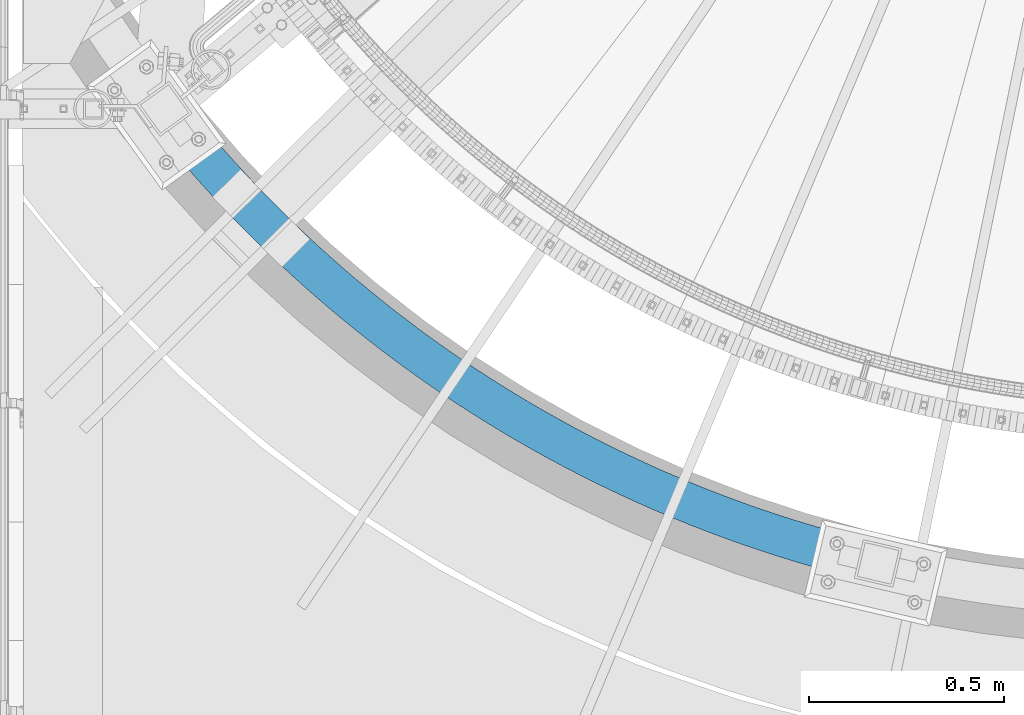
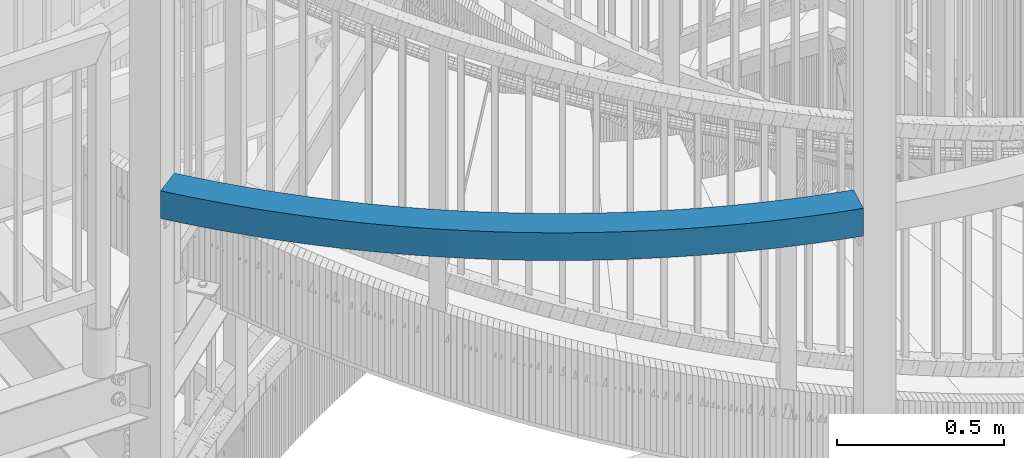
# One storey, part 337 of 975: 1 beam.
"""IFC2X3 building model written with IfcOpenShell, lengths in millimetres."""

from ifc_helpers import new_model, si_unit, frame, origin_with_axes, place, context, subcontext, project, spatial, faceted_brep, material, type_object, element, save


model = new_model("IFC2X3")

# Units and contexts
model_context = context("Model", 3, precision=1e-05, world=origin_with_axes())
body_context = subcontext(model_context, "Body", "Model", "MODEL_VIEW")
ifc_project = project(units=[si_unit("LENGTHUNIT", "METRE", prefix="MILLI"), si_unit("AREAUNIT", "SQUARE_METRE"), si_unit("VOLUMEUNIT", "CUBIC_METRE"), si_unit("MASSUNIT", "GRAM", prefix="KILO"), si_unit("TIMEUNIT", "SECOND"), si_unit("PLANEANGLEUNIT", "RADIAN"), si_unit("SOLIDANGLEUNIT", "STERADIAN"), si_unit("THERMODYNAMICTEMPERATUREUNIT", "DEGREE_CELSIUS"), si_unit("LUMINOUSINTENSITYUNIT", "LUMEN")], contexts=[model_context])

# Site, building, storey
site_placement = place(None, origin_with_axes())
site = spatial("IfcSite", under=ifc_project, at=site_placement, CompositionType="ELEMENT")
building_placement = place(site_placement, origin_with_axes())
building = spatial("IfcBuilding", under=site, at=building_placement, Name="Undefined", CompositionType="ELEMENT")
storey_placement = place(building_placement, origin_with_axes())
storey = spatial("IfcBuildingStorey", under=building, at=storey_placement, Name="Undefined", CompositionType="ELEMENT", Elevation=0.0)

# Beam
ifc_material = material()
beam_type = type_object("IfcBeamType", Name="HSS4X4X3/8", PredefinedType="NOTDEFINED")
beam_placement = place(storey_placement, frame((33982.1142771518, 198.286565354013, 4521.2), z_axis=(0.0, 0.0, 1.0), x_axis=(-0.831867275840489, 0.554974625893584, 0.0)))
element("IfcBeam", 1, at=beam_placement, inside=storey, type_object=beam_type, material=ifc_material, Name="BEAM", ObjectType="HSS4X4X3/8", context=body_context, shape_type="Brep", body=[
    faceted_brep([(2064.52279994458, 26.9212742150994, 50.8000000000002), (2064.52279994458, 26.9212742150994, -50.8000000000002), (2102.18524200268, 15.6378452218232, -50.8000000000002), (2102.18524200268, 15.6378452218232, 50.8000000000002), (2026.72628023623, 37.7470956417674, 50.8000000000002), (2026.72628023623, 37.7470956417674, -50.8000000000002), (1988.80124269562, 48.1137170378279, 50.8000000000002), (1988.80124269562, 48.1137170378279, -50.8000000000002), (1950.75326604555, 58.0196134870021, 50.8000000000002), (1950.75326604555, 58.0196134870021, -50.8000000000002), (1912.58794709301, 67.4633278450383, 50.8000000000002), (1912.58794709301, 67.4633278450383, -50.8000000000002), (1874.31089990586, 76.4434709540656, 50.8000000000002), (1874.31089990586, 76.4434709540656, -50.8000000000002), (1835.92775498707, 84.9587218469242, 50.8000000000002), (1835.92775498707, 84.9587218469242, -50.8000000000002), (1797.44415844641, 93.0078279414774, 50.8000000000002), (1797.44415844641, 93.0078279414774, -50.8000000000002), (1758.86577116999, 100.589605224886, 50.8000000000002), (1758.86577116999, 100.589605224886, -50.8000000000002), (1720.19826798746, 107.702938427748, 50.8000000000002), (1720.19826798746, 107.702938427748, -50.8000000000002), (1681.44733683736, 114.346781188171, 50.8000000000002), (1681.44733683736, 114.346781188171, -50.8000000000002), (1642.61867793034, 120.520156205686, 50.8000000000002), (1642.61867793034, 120.520156205686, -50.8000000000002), (1603.71800291069, 126.222155384992, 50.8000000000002), (1603.71800291069, 126.222155384992, -50.8000000000002), (1564.7510340162, 131.451939969578, 50.8000000000002), (1564.7510340162, 131.451939969578, -50.8000000000002), (1525.7235032364, 136.208740665035, 50.8000000000002), (1525.7235032364, 136.208740665035, -50.8000000000002), (1486.64115146937, 140.491857752302, 50.8000000000002), (1486.64115146937, 140.491857752302, -50.8000000000002), (1447.50972767731, 144.300661190511, 50.8000000000002), (1447.50972767731, 144.300661190511, -50.8000000000002), (1408.33498804084, 147.634590709735, 50.8000000000002), (1408.33498804084, 147.634590709735, -50.8000000000002), (1369.12269511228, 150.493155893342, 50.8000000000002), (1369.12269511228, 150.493155893342, -50.8000000000002), (1329.87861696798, 152.875936250188, 50.8000000000002), (1329.87861696798, 152.875936250188, -50.8000000000002), (1290.60852635988, 154.782581276435, 50.8000000000002), (1290.60852635988, 154.782581276435, -50.8000000000002), (1251.3181998663, 156.212810507124, 50.8000000000002), (1251.3181998663, 156.212810507124, -50.8000000000002), (1212.01341704224, 157.166413557436, 50.8000000000002), (1212.01341704224, 157.166413557436, -50.8000000000002), (1172.69995956921, 157.643250153615, 50.8000000000002), (1172.69995956921, 157.643250153615, -50.8000000000002), (1133.38361040472, 157.643250153633, 50.8000000000002), (1133.38361040472, 157.643250153633, -50.8000000000002), (1094.07015293168, 157.16641355749, 50.8000000000002), (1094.07015293168, 157.16641355749, -50.8000000000002), (1054.76537010762, 156.212810507219, 50.8000000000002), (1054.76537010762, 156.212810507219, -50.8000000000002), (1015.47504361405, 154.782581276566, 50.8000000000002), (1015.47504361405, 154.782581276566, -50.8000000000002), (976.204953005959, 152.875936250359, 50.8000000000002), (976.204953005959, 152.875936250359, -50.8000000000002), (936.960874861674, 150.49315589355, 50.8000000000002), (936.960874861674, 150.49315589355, -50.8000000000002), (897.74858193312, 147.634590709979, 50.8000000000002), (897.74858193312, 147.634590709979, -50.8000000000002), (858.573842296661, 144.300661190799, 50.8000000000002), (858.573842296661, 144.300661190799, -50.8000000000002), (819.442418504615, 140.491857752619, 50.8000000000002), (819.442418504615, 140.491857752619, -50.8000000000002), (780.360066737609, 136.208740665395, 50.8000000000002), (780.360066737609, 136.208740665395, -50.8000000000002), (741.332535957823, 131.451939969971, 50.8000000000002), (741.332535957823, 131.451939969971, -50.8000000000002), (702.365567063356, 126.222155385429, 50.8000000000002), (702.365567063356, 126.222155385429, -50.8000000000002), (663.464892043732, 120.520156206156, 50.8000000000002), (663.464892043732, 120.520156206156, -50.8000000000002), (624.636233136735, 114.34678118868, 50.8000000000002), (624.636233136735, 114.34678118868, -50.8000000000002), (585.885301986655, 107.702938428294, 50.8000000000002), (585.885301986655, 107.702938428294, -50.8000000000002), (547.217798804162, 100.589605225468, 50.8000000000002), (547.217798804162, 100.589605225468, -50.8000000000002), (508.639411527762, 93.0078279420995, 50.8000000000002), (508.639411527762, 93.0078279420995, -50.8000000000002), (470.155814987145, 84.9587218475826, 50.8000000000002), (470.155814987145, 84.9587218475826, -50.8000000000002), (431.772670068382, 76.4434709547604, 50.8000000000002), (431.772670068382, 76.4434709547604, -50.8000000000002), (393.49562288127, 67.4633278457695, 50.8000000000002), (393.49562288127, 67.4633278457695, -50.8000000000002), (355.33030392876, 58.019613487766, 50.8000000000002), (355.33030392876, 58.019613487766, -50.8000000000002), (317.282327278739, 48.1137170386282, 50.8000000000002), (317.282327278739, 48.1137170386282, -50.8000000000002), (279.357289738171, 37.7470956426077, 50.8000000000002), (279.357289738171, 37.7470956426077, -50.8000000000002), (241.560770029864, 26.9212742159798, 50.8000000000002), (241.560770029864, 26.9212742159798, -50.8000000000002), (203.898327971809, 15.6378452227364, 50.8000000000002), (203.898327971809, 15.6378452227364, -50.8000000000002), (166.375503659361, 3.89846844034764, 50.8000000000002), (166.375503659361, 3.89846844034764, -50.8000000000002), (128.997816650288, -8.29512928441181, 50.8000000000002), (128.997816650288, -8.29512928441181, -50.8000000000002), (91.7707651528508, -20.9411542894595, 50.8000000000002), (91.7707651528508, -20.9411542894595, -50.8000000000002), (65.5293185225273, -30.2118531842389, 50.8000000000002), (65.5293185225273, -30.2118531842389, -50.8000000000002), (58.5085467235222, 75.0598083367004, 50.8000000000002), (58.5085467235222, 75.0598083367004, -50.8000000000002), (29.9447402575825, 64.9686554835462, -50.8000000000002), (29.9447402575825, 64.9686554835462, 50.8000000000002), (96.9023636326565, 88.1021834145577, 50.8000000000002), (96.9023636326565, 88.1021834145577, -50.8000000000002), (135.451537252065, 100.677951295078, 50.8000000000002), (135.451537252065, 100.677951295078, -50.8000000000002), (174.150397049354, 112.785262099464, 50.8000000000002), (174.150397049354, 112.785262099464, -50.8000000000002), (212.993250473493, 124.422334858333, 50.8000000000002), (212.993250473493, 124.422334858333, -50.8000000000002), (251.974383792185, 135.587457773683, 50.8000000000002), (251.974383792185, 135.587457773683, -50.8000000000002), (291.088062932333, 146.278988470724, 50.8000000000002), (291.088062932333, 146.278988470724, -50.8000000000002), (330.32853432354, 156.495354239451, 50.8000000000002), (330.32853432354, 156.495354239451, -50.8000000000002), (369.690025744425, 166.235052265984, 50.8000000000002), (369.690025744425, 166.235052265984, -50.8000000000002), (409.166747171734, 175.496649853649, 50.8000000000002), (409.166747171734, 175.496649853649, -50.8000000000002), (448.752891632008, 184.278784633694, 50.8000000000002), (448.752891632008, 184.278784633694, -50.8000000000002), (488.442636055832, 192.580164765735, 50.8000000000002), (488.442636055832, 192.580164765735, -50.8000000000002), (528.230142134355, 200.399569127738, 50.8000000000002), (528.230142134355, 200.399569127738, -50.8000000000002), (568.109557178119, 207.735847495678, 50.8000000000002), (568.109557178119, 207.735847495678, -50.8000000000002), (608.075014977992, 214.587920712729, 50.8000000000002), (608.075014977992, 214.587920712729, -50.8000000000002), (648.120636668053, 220.954780847991, 50.8000000000002), (648.120636668053, 220.954780847991, -50.8000000000002), (688.240531590378, 226.835491344769, 50.8000000000002), (688.240531590378, 226.835491344769, -50.8000000000002), (728.42879816156, 232.229187158337, 50.8000000000002), (728.42879816156, 232.229187158337, -50.8000000000002), (768.679524740801, 237.135074883179, 50.8000000000002), (768.679524740801, 237.135074883179, -50.8000000000002), (808.98679049953, 241.552432869714, 50.8000000000002), (808.98679049953, 241.552432869714, -50.8000000000002), (849.34466629232, 245.480611330429, 50.8000000000002), (849.34466629232, 245.480611330429, -50.8000000000002), (889.7472155291, 248.919032435475, 50.8000000000002), (889.7472155291, 248.919032435475, -50.8000000000002), (930.188495048376, 251.867190397661, 50.8000000000002), (930.188495048376, 251.867190397661, -50.8000000000002), (970.662555991479, 254.324651546856, 50.8000000000002), (970.662555991479, 254.324651546856, -50.8000000000002), (1011.16344467765, 256.291054393772, 50.8000000000002), (1011.16344467765, 256.291054393772, -50.8000000000002), (1051.6852034798, 257.766109683165, 50.8000000000002), (1051.6852034798, 257.766109683165, -50.8000000000002), (1092.22187170087, 258.749600436349, 50.8000000000002), (1092.22187170087, 258.749600436349, -50.8000000000002), (1132.76748645064, 259.241381983138, 50.8000000000002), (1132.76748645064, 259.241381983138, -50.8000000000002), (1173.31608352288, 259.24138198312, 50.8000000000002), (1173.31608352288, 259.24138198312, -50.8000000000002), (1213.86169827265, 258.749600436291, 50.8000000000002), (1213.86169827265, 258.749600436291, -50.8000000000002), (1254.39836649372, 257.766109683067, 50.8000000000002), (1254.39836649372, 257.766109683067, -50.8000000000002), (1294.92012529587, 256.291054393638, 50.8000000000002), (1294.92012529587, 256.291054393638, -50.8000000000002), (1335.42101398206, 254.324651546678, 50.8000000000002), (1335.42101398206, 254.324651546678, -50.8000000000002), (1375.89507492517, 251.867190397446, 50.8000000000002), (1375.89507492517, 251.867190397446, -50.8000000000002), (1416.33635444446, 248.919032435224, 50.8000000000002), (1416.33635444446, 248.919032435224, -50.8000000000002), (1456.73890368125, 245.480611330138, 50.8000000000002), (1456.73890368125, 245.480611330138, -50.8000000000002), (1497.09677947406, 241.552432869383, 50.8000000000002), (1497.09677947406, 241.552432869383, -50.8000000000002), (1537.4040452328, 237.135074882808, 50.8000000000002), (1537.4040452328, 237.135074882808, -50.8000000000002), (1577.65477181207, 232.229187157925, 50.8000000000002), (1577.65477181207, 232.229187157925, -50.8000000000002), (1617.84303838327, 226.835491344322, 50.8000000000002), (1617.84303838327, 226.835491344322, -50.8000000000002), (1657.96293330561, 220.954780847507, 50.8000000000002), (1657.96293330561, 220.954780847507, -50.8000000000002), (1698.0085549957, 214.587920712205, 50.8000000000002), (1698.0085549957, 214.587920712205, -50.8000000000002), (1737.9740127956, 207.735847495118, 50.8000000000002), (1737.9740127956, 207.735847495118, -50.8000000000002), (1777.8534278394, 200.399569127134, 50.8000000000002), (1777.8534278394, 200.399569127134, -50.8000000000002), (1817.64093391795, 192.580164765095, 50.8000000000002), (1817.64093391795, 192.580164765095, -50.8000000000002), (1857.33067834181, 184.278784633017, 50.8000000000002), (1857.33067834181, 184.278784633017, -50.8000000000002), (1896.91682280212, 175.496649852932, 50.8000000000002), (1896.91682280212, 175.496649852932, -50.8000000000002), (1936.39354422946, 166.23505226523, 50.8000000000002), (1936.39354422946, 166.23505226523, -50.8000000000002), (1975.75503565039, 156.495354238661, 50.8000000000002), (1975.75503565039, 156.495354238661, -50.8000000000002), (2014.99550704163, 146.278988469894, 50.8000000000002), (2014.99550704163, 146.278988469894, -50.8000000000002), (2054.10918618183, 135.587457772814, 50.8000000000002), (2054.10918618183, 135.587457772814, -50.8000000000002), (2093.09031950056, 124.422334857423, 50.8000000000002), (2093.09031950056, 124.422334857423, -50.8000000000002), (2131.93317292475, 112.785262098525, 50.8000000000002), (2131.93317292475, 112.785262098525, -50.8000000000002), (2141.03301296791, 109.938289545582, 50.8000000000002), (2141.03301296791, 109.938289545582, -50.8000000000002), (2105.39789619187, 14.6327354335917, -50.8000000000002), (2105.39789619187, 14.6327354335917, 50.8000000000002), (2067.20100490296, 36.0619986503189, -41.2749999999996), (2067.20100490296, 36.0619986503189, 41.2749999999996), (2104.97411052662, 24.7454155540145, 41.2749999999996), (2104.97411052662, 24.7454155540145, -41.2749999999996), (2029.29342766863, 46.9196295915535, -41.2749999999996), (2029.29342766863, 46.9196295915535, 41.2749999999996), (1991.25695497806, 57.3167112345836, -41.2749999999996), (1991.25695497806, 57.3167112345836, 41.2749999999996), (1953.09718194601, 67.2517141824683, -41.2749999999996), (1953.09718194601, 67.2517141824683, 41.2749999999996), (1914.81972182456, 76.7231770094331, -41.2749999999996), (1914.81972182456, 76.7231770094331, 41.2749999999996), (1876.43020517739, 85.729706475835, -41.2749999999996), (1876.43020517739, 85.729706475835, 41.2749999999996), (1837.93427905158, 94.2699777331181, -41.2749999999996), (1837.93427905158, 94.2699777331181, 41.2749999999996), (1799.33760614687, 102.34273451869, -41.2749999999996), (1799.33760614687, 102.34273451869, 41.2749999999996), (1760.64586398274, 109.946789340724, -41.2749999999996), (1760.64586398274, 109.946789340724, 41.2749999999996), (1721.86474406323, 117.081023652816, -41.2749999999996), (1721.86474406323, 117.081023652816, 41.2749999999996), (1682.9999510397, 123.744388018553, -41.2749999999996), (1682.9999510397, 123.744388018553, 41.2749999999996), (1644.05720187177, 129.935902265857, -41.2749999999996), (1644.05720187177, 129.935902265857, 41.2749999999996), (1605.04222498624, 135.654655631181, -41.2749999999996), (1605.04222498624, 135.654655631181, 41.2749999999996), (1565.96075943457, 140.899806893485, -41.2749999999996), (1565.96075943457, 140.899806893485, 41.2749999999996), (1526.81855404856, 145.670584497951, -41.2749999999996), (1526.81855404856, 145.670584497951, 41.2749999999996), (1487.62136659481, 149.966286669529, -41.2749999999996), (1487.62136659481, 149.966286669529, 41.2749999999996), (1448.37496292768, 153.786281516106, -41.2749999999996), (1448.37496292768, 153.786281516106, 41.2749999999996), (1409.08511614118, 157.130007121497, -41.2749999999996), (1409.08511614118, 157.130007121497, 41.2749999999996), (1369.75760571973, 159.996971628101, -41.2749999999996), (1369.75760571973, 159.996971628101, 41.2749999999996), (1330.39821668805, 162.386753309234, -41.2749999999996), (1330.39821668805, 162.386753309234, 41.2749999999996), (1291.01273876013, 164.299000631174, -41.2749999999996), (1291.01273876013, 164.299000631174, 41.2749999999996), (1251.60696548762, 165.733432304867, -41.2749999999996), (1251.60696548762, 165.733432304867, 41.2749999999996), (1212.1866934076, 166.689837327329, -41.2749999999996), (1212.1866934076, 166.689837327329, 41.2749999999996), (1172.75772118986, 167.168075012629, -41.2749999999996), (1172.75772118986, 167.168075012629, 41.2749999999996), (1133.32584878402, 167.168075012647, -41.2749999999996), (1133.32584878402, 167.168075012647, 41.2749999999996), (1093.89687656629, 166.689837327383, -41.2749999999996), (1093.89687656629, 166.689837327383, 41.2749999999996), (1054.47660448626, 165.733432304965, -41.2749999999996), (1054.47660448626, 165.733432304965, 41.2749999999996), (1015.07083121376, 164.299000631305, -41.2749999999996), (1015.07083121376, 164.299000631305, 41.2749999999996), (975.685353285851, 162.386753309405, -41.2749999999996), (975.685353285851, 162.386753309405, 41.2749999999996), (936.325964254178, 159.996971628309, -41.2749999999996), (936.325964254178, 159.996971628309, 41.2749999999996), (896.998453832744, 157.130007121741, -41.2749999999996), (896.998453832744, 157.130007121741, 41.2749999999996), (857.708607046257, 153.78628151639, -41.2749999999996), (857.708607046257, 153.78628151639, 41.2749999999996), (818.462203379138, 149.966286669849, -41.2749999999996), (818.462203379138, 149.966286669849, 41.2749999999996), (779.265015925408, 145.670584498315, -41.2749999999996), (779.265015925408, 145.670584498315, 41.2749999999996), (740.122810539426, 140.899806893882, -41.2749999999996), (740.122810539426, 140.899806893882, 41.2749999999996), (701.041344987767, 135.654655631617, -41.2749999999996), (701.041344987767, 135.654655631617, 41.2749999999996), (662.026368102262, 129.93590226633, -41.2749999999996), (662.026368102262, 129.93590226633, 41.2749999999996), (623.08361893435, 123.744388019062, -41.2749999999996), (623.08361893435, 123.744388019062, 41.2749999999996), (584.218825910855, 117.081023653365, -41.2749999999996), (584.218825910855, 117.081023653365, 41.2749999999996), (545.437705991368, 109.946789341306, -41.2749999999996), (545.437705991368, 109.946789341306, 41.2749999999996), (506.74596382727, 102.342734519316, -41.2749999999996), (506.74596382727, 102.342734519316, 41.2749999999996), (468.1492909226, 94.2699777337803, -41.2749999999996), (468.1492909226, 94.2699777337803, 41.2749999999996), (429.653364796821, 85.7297064765298, -41.2749999999996), (429.653364796821, 85.7297064765298, 41.2749999999996), (391.263848149691, 76.7231770101644, -41.2749999999996), (391.263848149691, 76.7231770101644, 41.2749999999996), (352.986388028272, 67.2517141832359, -41.2749999999996), (352.986388028272, 67.2517141832359, 41.2749999999996), (314.826614996266, 57.3167112353913, -41.2749999999996), (314.826614996266, 57.3167112353913, 41.2749999999996), (276.790142305737, 46.9196295923975, -41.2749999999996), (276.790142305737, 46.9196295923975, 41.2749999999996), (238.882565071453, 36.0619986511956, -41.2749999999996), (238.882565071453, 36.0619986511956, 41.2749999999996), (201.109459447835, 24.7454155549349, -41.2749999999996), (201.109459447835, 24.7454155549349, 41.2749999999996), (163.476381808679, 12.9715449579817, -41.2749999999996), (163.476381808679, 12.9715449579817, 41.2749999999996), (125.988867929886, 0.742118781119643, -41.2749999999996), (125.988867929886, 0.742118781119643, 41.2749999999996), (88.6524321750985, -11.9410640432543, -41.2749999999996), (88.6524321750985, -11.9410640432543, 41.2749999999996), (62.1932643101827, -21.2886804966365, -41.2749999999996), (62.1932643101827, -21.2886804966365, 41.2749999999996), (33.2807944699271, 56.0454827959438, -41.2749999999996), (33.2807944699271, 56.0454827959438, 41.2749999999996), (61.6268797012672, 66.0597180904952, -41.2749999999996), (61.6268797012672, 66.0597180904952, 41.2749999999996), (99.9113123530624, 79.0649353490298, -41.2749999999996), (99.9113123530624, 79.0649353490298, 41.2749999999996), (138.350659102751, 91.6048747774475, -41.2749999999996), (138.350659102751, 91.6048747774475, 41.2749999999996), (176.939265573335, 103.677691767272, -41.2749999999996), (176.939265573335, 103.677691767272, 41.2749999999996), (215.671455431904, 115.281610423113, -41.2749999999996), (215.671455431904, 115.281610423113, 41.2749999999996), (254.541531224619, 126.414923823897, -41.2749999999996), (254.541531224619, 126.414923823897, 41.2749999999996), (293.543775214803, 137.075994273964, -41.2749999999996), (293.543775214803, 137.075994273964, 41.2749999999996), (332.672450224025, 147.263253543981, -41.2749999999996), (332.672450224025, 147.263253543981, 41.2749999999996), (371.921800476004, 156.975203101592, -41.2749999999996), (371.921800476004, 156.975203101592, 41.2749999999996), (411.286052443291, 166.210414331876, -41.2749999999996), (411.286052443291, 166.210414331876, 41.2749999999996), (450.759415696553, 174.967528747497, -41.2749999999996), (450.759415696553, 174.967528747497, 41.2749999999996), (490.336083756323, 183.245258188519, -41.2749999999996), (490.336083756323, 183.245258188519, 41.2749999999996), (530.010234947145, 191.0423850119, -41.2749999999996), (530.010234947145, 191.0423850119, 41.2749999999996), (569.776033253926, 198.357762270614, -41.2749999999996), (569.776033253926, 198.357762270614, 41.2749999999996), (609.627629180377, 205.190313882351, -41.2749999999996), (609.627629180377, 205.190313882351, 41.2749999999996), (649.559160609522, 211.53903478782, -41.2749999999996), (649.559160609522, 211.53903478782, 41.2749999999996), (689.564753665971, 217.402991098581, -41.2749999999996), (689.564753665971, 217.402991098581, 41.2749999999996), (729.638523579957, 222.781320234426, -41.2749999999996), (729.638523579957, 222.781320234426, 41.2749999999996), (769.774575553005, 227.673231050263, -41.2749999999996), (769.774575553005, 227.673231050263, 41.2749999999996), (809.967005625003, 232.078003952487, -41.2749999999996), (809.967005625003, 232.078003952487, 41.2749999999996), (850.20990154273, 235.994991004842, -41.2749999999996), (850.20990154273, 235.994991004842, 41.2749999999996), (890.497343629475, 239.423616023709, -41.2749999999996), (890.497343629475, 239.423616023709, 41.2749999999996), (930.823405655872, 242.363374662902, -41.2749999999996), (930.823405655872, 242.363374662902, 41.2749999999996), (971.182155711591, 244.81383448781, -41.2749999999996), (971.182155711591, 244.81383448781, 41.2749999999996), (1011.56765707794, 246.774635039037, -41.2749999999996), (1011.56765707794, 246.774635039037, 41.2749999999996), (1051.97396910116, 248.245487885419, -41.2749999999996), (1051.97396910116, 248.245487885419, 41.2749999999996), (1092.39514806626, 249.22617666646, -41.2749999999996), (1092.39514806626, 249.22617666646, 41.2749999999996), (1132.82524807133, 249.716557124124, -41.2749999999996), (1132.82524807133, 249.716557124124, 41.2749999999996), (1173.25832190222, 249.716557124102, -41.2749999999996), (1173.25832190222, 249.716557124102, 41.2749999999996), (1213.6884219073, 249.226176666398, -41.2749999999996), (1213.6884219073, 249.226176666398, 41.2749999999996), (1254.1096008724, 248.245487885324, -41.2749999999996), (1254.1096008724, 248.245487885324, 41.2749999999996), (1294.51591289563, 246.774635038902, -41.2749999999996), (1294.51591289563, 246.774635038902, 41.2749999999996), (1334.90141426199, 244.813834487632, -41.2749999999996), (1334.90141426199, 244.813834487632, 41.2749999999996), (1375.26016431771, 242.363374662687, -41.2749999999996), (1375.26016431771, 242.363374662687, 41.2749999999996), (1415.58622634412, 239.423616023458, -41.2749999999996), (1415.58622634412, 239.423616023458, 41.2749999999996), (1455.87366843088, 235.994991004547, -41.2749999999996), (1455.87366843088, 235.994991004547, 41.2749999999996), (1496.11656434862, 232.078003952156, -41.2749999999996), (1496.11656434862, 232.078003952156, 41.2749999999996), (1536.30899442064, 227.673231049892, -41.2749999999996), (1536.30899442064, 227.673231049892, 41.2749999999996), (1576.4450463937, 222.781320234018, -41.2749999999996), (1576.4450463937, 222.781320234018, 41.2749999999996), (1616.51881630771, 217.402991098133, -41.2749999999996), (1616.51881630771, 217.402991098133, 41.2749999999996), (1656.52440936418, 211.539034787333, -41.2749999999996), (1656.52440936418, 211.539034787333, 41.2749999999996), (1696.45594079336, 205.190313881827, -41.2749999999996), (1696.45594079336, 205.190313881827, 41.2749999999996), (1736.30753671984, 198.35776227005, -41.2749999999996), (1736.30753671984, 198.35776227005, 41.2749999999996), (1776.07333502664, 191.0423850113, -41.2749999999996), (1776.07333502664, 191.0423850113, 41.2749999999996), (1815.7474862175, 183.245258187879, -41.2749999999996), (1815.7474862175, 183.245258187879, 41.2749999999996), (1855.3241542773, 174.96752874682, -41.2749999999996), (1855.3241542773, 174.96752874682, 41.2749999999996), (1894.79751753059, 166.210414331163, -41.2749999999996), (1894.79751753059, 166.210414331163, 41.2749999999996), (1934.16176949792, 156.975203100836, -41.2749999999996), (1934.16176949792, 156.975203100836, 41.2749999999996), (1973.41111974993, 147.263253543188, -41.2749999999996), (1973.41111974993, 147.263253543188, 41.2749999999996), (2012.5397947592, 137.075994273138, -41.2749999999996), (2012.5397947592, 137.075994273138, 41.2749999999996), (2051.54203874943, 126.414923823031, -41.2749999999996), (2051.54203874943, 126.414923823031, 41.2749999999996), (2090.41211454219, 115.281610422211, -41.2749999999996), (2090.41211454219, 115.281610422211, 41.2749999999996), (2129.1443044008, 103.67769176633, -41.2749999999996), (2129.1443044008, 103.67769176633, 41.2749999999996), (2137.69222077015, 101.003393847586, 41.2749999999996), (2108.73868838963, 23.5676311315947, 41.2749999999996), (2108.73868838963, 23.5676311315947, -41.2749999999996), (2137.69222077015, 101.003393847586, -41.2749999999996)], [[[0, 1, 2, 3]], [[4, 5, 1, 0]], [[6, 7, 5, 4]], [[8, 9, 7, 6]], [[10, 11, 9, 8]], [[12, 13, 11, 10]], [[14, 15, 13, 12]], [[16, 17, 15, 14]], [[18, 19, 17, 16]], [[20, 21, 19, 18]], [[22, 23, 21, 20]], [[24, 25, 23, 22]], [[26, 27, 25, 24]], [[28, 29, 27, 26]], [[30, 31, 29, 28]], [[32, 33, 31, 30]], [[34, 35, 33, 32]], [[36, 37, 35, 34]], [[38, 39, 37, 36]], [[40, 41, 39, 38]], [[42, 43, 41, 40]], [[44, 45, 43, 42]], [[46, 47, 45, 44]], [[48, 49, 47, 46]], [[50, 51, 49, 48]], [[52, 53, 51, 50]], [[54, 55, 53, 52]], [[56, 57, 55, 54]], [[58, 59, 57, 56]], [[60, 61, 59, 58]], [[62, 63, 61, 60]], [[64, 65, 63, 62]], [[66, 67, 65, 64]], [[68, 69, 67, 66]], [[70, 71, 69, 68]], [[72, 73, 71, 70]], [[74, 75, 73, 72]], [[76, 77, 75, 74]], [[78, 79, 77, 76]], [[80, 81, 79, 78]], [[82, 83, 81, 80]], [[84, 85, 83, 82]], [[86, 87, 85, 84]], [[88, 89, 87, 86]], [[90, 91, 89, 88]], [[92, 93, 91, 90]], [[94, 95, 93, 92]], [[96, 97, 95, 94]], [[98, 99, 97, 96]], [[100, 101, 99, 98]], [[102, 103, 101, 100]], [[104, 105, 103, 102]], [[105, 104, 106, 107]], [[108, 109, 110, 111]], [[109, 108, 112, 113]], [[113, 112, 114, 115]], [[115, 114, 116, 117]], [[117, 116, 118, 119]], [[119, 118, 120, 121]], [[121, 120, 122, 123]], [[123, 122, 124, 125]], [[125, 124, 126, 127]], [[127, 126, 128, 129]], [[129, 128, 130, 131]], [[131, 130, 132, 133]], [[133, 132, 134, 135]], [[135, 134, 136, 137]], [[137, 136, 138, 139]], [[139, 138, 140, 141]], [[141, 140, 142, 143]], [[143, 142, 144, 145]], [[145, 144, 146, 147]], [[147, 146, 148, 149]], [[149, 148, 150, 151]], [[151, 150, 152, 153]], [[153, 152, 154, 155]], [[155, 154, 156, 157]], [[157, 156, 158, 159]], [[159, 158, 160, 161]], [[161, 160, 162, 163]], [[163, 162, 164, 165]], [[165, 164, 166, 167]], [[167, 166, 168, 169]], [[169, 168, 170, 171]], [[171, 170, 172, 173]], [[173, 172, 174, 175]], [[175, 174, 176, 177]], [[177, 176, 178, 179]], [[179, 178, 180, 181]], [[181, 180, 182, 183]], [[183, 182, 184, 185]], [[185, 184, 186, 187]], [[187, 186, 188, 189]], [[189, 188, 190, 191]], [[191, 190, 192, 193]], [[193, 192, 194, 195]], [[195, 194, 196, 197]], [[197, 196, 198, 199]], [[199, 198, 200, 201]], [[201, 200, 202, 203]], [[203, 202, 204, 205]], [[205, 204, 206, 207]], [[207, 206, 208, 209]], [[209, 208, 210, 211]], [[211, 210, 212, 213]], [[213, 212, 214, 215]], [[215, 214, 216, 217]], [[2, 1, 5, 7, 9, 11, 13, 15, 17, 19, 21, 23, 25, 27, 29, 31, 33, 35, 37, 39, 41, 43, 45, 47, 49, 51, 53, 55, 57, 59, 61, 63, 65, 67, 69, 71, 73, 75, 77, 79, 81, 83, 85, 87, 89, 91, 93, 95, 97, 99, 101, 103, 105, 107, 110, 109, 113, 115, 117, 119, 121, 123, 125, 127, 129, 131, 133, 135, 137, 139, 141, 143, 145, 147, 149, 151, 153, 155, 157, 159, 161, 163, 165, 167, 169, 171, 173, 175, 177, 179, 181, 183, 185, 187, 189, 191, 193, 195, 197, 199, 201, 203, 205, 207, 209, 211, 213, 215, 217, 218]], [[3, 2, 218, 219]], [[214, 212, 210, 208, 206, 204, 202, 200, 198, 196, 194, 192, 190, 188, 186, 184, 182, 180, 178, 176, 174, 172, 170, 168, 166, 164, 162, 160, 158, 156, 154, 152, 150, 148, 146, 144, 142, 140, 138, 136, 134, 132, 130, 128, 126, 124, 122, 120, 118, 116, 114, 112, 108, 111, 106, 104, 102, 100, 98, 96, 94, 92, 90, 88, 86, 84, 82, 80, 78, 76, 74, 72, 70, 68, 66, 64, 62, 60, 58, 56, 54, 52, 50, 48, 46, 44, 42, 40, 38, 36, 34, 32, 30, 28, 26, 24, 22, 20, 18, 16, 14, 12, 10, 8, 6, 4, 0, 3, 219, 216]], [[220, 221, 222, 223]], [[224, 225, 221, 220]], [[226, 227, 225, 224]], [[228, 229, 227, 226]], [[230, 231, 229, 228]], [[232, 233, 231, 230]], [[234, 235, 233, 232]], [[236, 237, 235, 234]], [[238, 239, 237, 236]], [[240, 241, 239, 238]], [[242, 243, 241, 240]], [[244, 245, 243, 242]], [[246, 247, 245, 244]], [[248, 249, 247, 246]], [[250, 251, 249, 248]], [[252, 253, 251, 250]], [[254, 255, 253, 252]], [[256, 257, 255, 254]], [[258, 259, 257, 256]], [[260, 261, 259, 258]], [[262, 263, 261, 260]], [[264, 265, 263, 262]], [[266, 267, 265, 264]], [[268, 269, 267, 266]], [[270, 271, 269, 268]], [[272, 273, 271, 270]], [[274, 275, 273, 272]], [[276, 277, 275, 274]], [[278, 279, 277, 276]], [[280, 281, 279, 278]], [[282, 283, 281, 280]], [[284, 285, 283, 282]], [[286, 287, 285, 284]], [[288, 289, 287, 286]], [[290, 291, 289, 288]], [[292, 293, 291, 290]], [[294, 295, 293, 292]], [[296, 297, 295, 294]], [[298, 299, 297, 296]], [[300, 301, 299, 298]], [[302, 303, 301, 300]], [[304, 305, 303, 302]], [[306, 307, 305, 304]], [[308, 309, 307, 306]], [[310, 311, 309, 308]], [[312, 313, 311, 310]], [[314, 315, 313, 312]], [[316, 317, 315, 314]], [[318, 319, 317, 316]], [[320, 321, 319, 318]], [[322, 323, 321, 320]], [[324, 325, 323, 322]], [[325, 324, 326, 327]], [[110, 107, 106, 111], [328, 329, 327, 326]], [[330, 331, 329, 328]], [[331, 330, 332, 333]], [[333, 332, 334, 335]], [[335, 334, 336, 337]], [[337, 336, 338, 339]], [[339, 338, 340, 341]], [[341, 340, 342, 343]], [[343, 342, 344, 345]], [[345, 344, 346, 347]], [[347, 346, 348, 349]], [[349, 348, 350, 351]], [[351, 350, 352, 353]], [[353, 352, 354, 355]], [[355, 354, 356, 357]], [[357, 356, 358, 359]], [[359, 358, 360, 361]], [[361, 360, 362, 363]], [[363, 362, 364, 365]], [[365, 364, 366, 367]], [[367, 366, 368, 369]], [[369, 368, 370, 371]], [[371, 370, 372, 373]], [[373, 372, 374, 375]], [[375, 374, 376, 377]], [[377, 376, 378, 379]], [[379, 378, 380, 381]], [[381, 380, 382, 383]], [[383, 382, 384, 385]], [[385, 384, 386, 387]], [[387, 386, 388, 389]], [[389, 388, 390, 391]], [[391, 390, 392, 393]], [[393, 392, 394, 395]], [[395, 394, 396, 397]], [[397, 396, 398, 399]], [[399, 398, 400, 401]], [[401, 400, 402, 403]], [[403, 402, 404, 405]], [[405, 404, 406, 407]], [[407, 406, 408, 409]], [[409, 408, 410, 411]], [[411, 410, 412, 413]], [[413, 412, 414, 415]], [[415, 414, 416, 417]], [[417, 416, 418, 419]], [[419, 418, 420, 421]], [[421, 420, 422, 423]], [[423, 422, 424, 425]], [[425, 424, 426, 427]], [[427, 426, 428, 429]], [[429, 428, 430, 431]], [[431, 430, 432, 433]], [[433, 432, 434, 435]], [[222, 221, 225, 227, 229, 231, 233, 235, 237, 239, 241, 243, 245, 247, 249, 251, 253, 255, 257, 259, 261, 263, 265, 267, 269, 271, 273, 275, 277, 279, 281, 283, 285, 287, 289, 291, 293, 295, 297, 299, 301, 303, 305, 307, 309, 311, 313, 315, 317, 319, 321, 323, 325, 327, 329, 331, 333, 335, 337, 339, 341, 343, 345, 347, 349, 351, 353, 355, 357, 359, 361, 363, 365, 367, 369, 371, 373, 375, 377, 379, 381, 383, 385, 387, 389, 391, 393, 395, 397, 399, 401, 403, 405, 407, 409, 411, 413, 415, 417, 419, 421, 423, 425, 427, 429, 431, 433, 435, 436, 437]], [[223, 222, 437, 438]], [[434, 432, 430, 428, 426, 424, 422, 420, 418, 416, 414, 412, 410, 408, 406, 404, 402, 400, 398, 396, 394, 392, 390, 388, 386, 384, 382, 380, 378, 376, 374, 372, 370, 368, 366, 364, 362, 360, 358, 356, 354, 352, 350, 348, 346, 344, 342, 340, 338, 336, 334, 332, 330, 328, 326, 324, 322, 320, 318, 316, 314, 312, 310, 308, 306, 304, 302, 300, 298, 296, 294, 292, 290, 288, 286, 284, 282, 280, 278, 276, 274, 272, 270, 268, 266, 264, 262, 260, 258, 256, 254, 252, 250, 248, 246, 244, 242, 240, 238, 236, 234, 232, 230, 228, 226, 224, 220, 223, 438, 439]], [[435, 434, 439, 436]], [[218, 217, 216, 219], [438, 437, 436, 439]]]),
])

save(model, "model.ifc")
